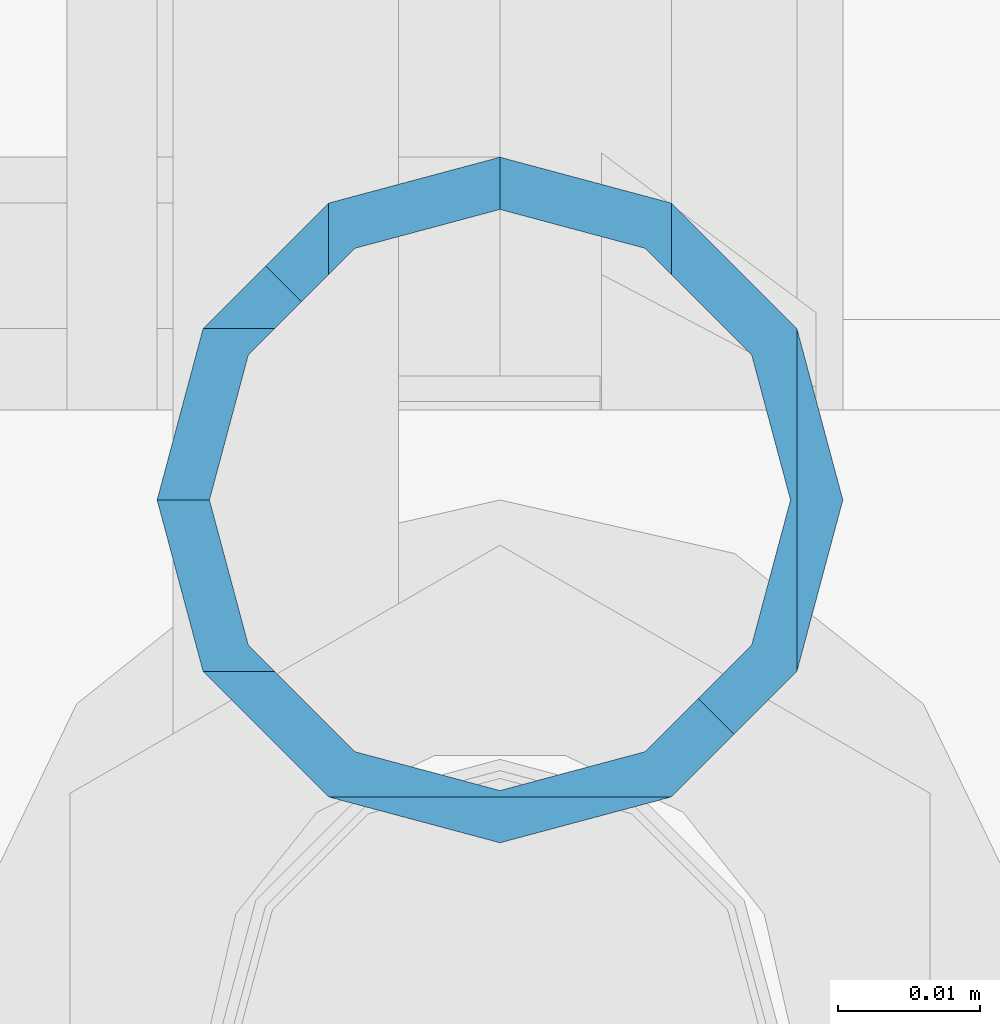
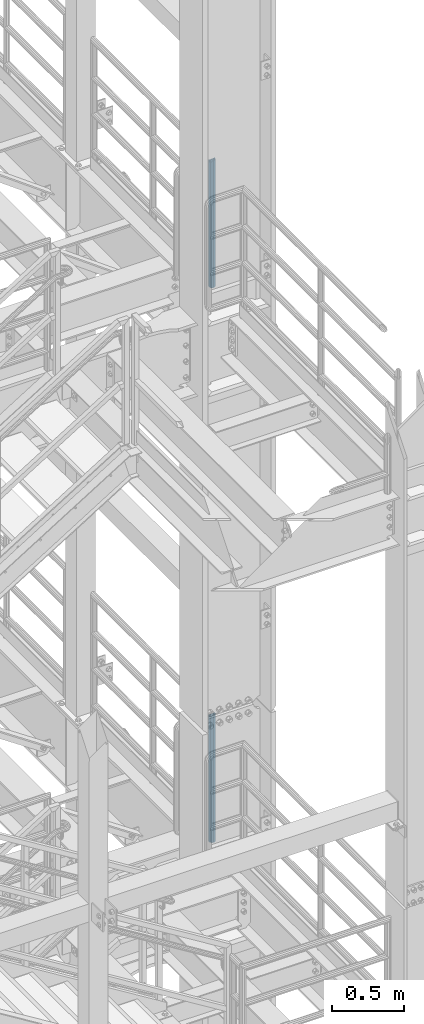
# One storey, part 662 of 1876: 2 columns, 2 elements without a shape of their own.
"""IFC2X3 building model written with IfcOpenShell, lengths in millimetres."""

from ifc_helpers import new_model, si_unit, frame, origin_with_axes, place, context, subcontext, project, spatial, faceted_brep, material, type_object, element, aggregate, save


model = new_model("IFC2X3")

# Units and contexts
model_context = context("Model", 3, precision=1e-05, world=origin_with_axes())
body_context = subcontext(model_context, "Body", "Model", "MODEL_VIEW")
ifc_project = project(units=[si_unit("LENGTHUNIT", "METRE", prefix="MILLI"), si_unit("AREAUNIT", "SQUARE_METRE"), si_unit("VOLUMEUNIT", "CUBIC_METRE"), si_unit("MASSUNIT", "GRAM", prefix="KILO"), si_unit("TIMEUNIT", "SECOND"), si_unit("PLANEANGLEUNIT", "RADIAN"), si_unit("SOLIDANGLEUNIT", "STERADIAN"), si_unit("THERMODYNAMICTEMPERATUREUNIT", "DEGREE_CELSIUS"), si_unit("LUMINOUSINTENSITYUNIT", "LUMEN")], contexts=[model_context])

# Site, building, storey
site_placement = place(None, origin_with_axes())
site = spatial("IfcSite", under=ifc_project, at=site_placement, CompositionType="ELEMENT")
building_placement = place(site_placement, origin_with_axes())
building = spatial("IfcBuilding", under=site, at=building_placement, Name="Undefined", CompositionType="ELEMENT")
storey_placement = place(building_placement, origin_with_axes())
storey = spatial("IfcBuildingStorey", under=building, at=storey_placement, Name="Undefined", CompositionType="ELEMENT", Elevation=0.0)

# Assembly, column
assembly_1_placement = place(storey_placement, origin_with_axes())
assembly_1 = element("IfcElementAssembly", 1, at=assembly_1_placement, inside=storey, Name="RAIL", AssemblyPlace="NOTDEFINED", PredefinedType="RIGID_FRAME")
ifc_material = material()
column_type = type_object("IfcColumnType", Name="PIPE1-1/2SCH40", PredefinedType="NOTDEFINED")
column_1_placement = place(assembly_1_placement, frame((7620.0, -4356.10000000001, 17983.2), z_axis=(0.0, 1.0, 0.0), x_axis=(0.0, 0.0, 1.0)))
column_1 = element("IfcColumn", 2, at=column_1_placement, type_object=column_type, material=ifc_material, Name="POST", ObjectType="PIPE1-1/2SCH40", context=body_context, shape_type="Brep", body=[
    faceted_brep([(1076.325, 0.0, -24.1300000000001), (1064.26, 12.065, -20.8971929933186), (1064.26, -12.0650000000001, -20.8971929933186), (1059.84389372908, 16.4810867391852, -16.481106254133), (1057.32835795174, 13.9655509593595, -13.9655704718216), (1061.07042843786, 10.2235000000001, -17.7076214311801), (1063.80980700668, 0.0, -20.4470000000001), (1061.07042843786, -10.2235000000001, -17.7076214311801), (1055.42780700668, -15.8661214311742, -12.065000000006), (1055.42780700668, -20.8971929933184, -12.0649999999996), (1054.93437856882, -17.7076214311801, -10.2235000000001), (1052.195, -20.4470000000001, 0.0), (1052.195, -24.1300000000001, 0.0), (1054.93437856882, -17.7076214311801, 10.2235000000001), (1055.42780700668, -15.8661214311869, 12.0649999999932), (1055.42780700668, -20.8971929933184, 12.0649999999996), (1057.32837749183, -13.9655704718189, 13.9655509593613), (1059.84391327663, -16.4811062541312, 16.481086739188), (1055.42780700668, -12.0650000000001, 15.8661214311805), (1055.42780700668, -12.0650000000001, 20.8971929933186), (1054.93437856882, -10.2235000000001, 17.7076214311801), (1052.195, 0.0, 20.4470000000001), (1052.195, 0.0, 24.1300000000001), (1054.93437856882, 10.2235000000001, 17.7076214311801), (1055.42780700668, 12.0650000000001, 15.8661214311805), (1055.42780700668, 12.0650000000001, 20.8971929933186), (1076.325, 24.1300000000001, 0.0), (1064.26, 20.8971929933184, 12.0649999999996), (1064.25999999999, 20.8971929933186, -12.0649999999996), (1061.07042843786, 17.7076214311803, 10.2235000000001), (1063.80980700668, 20.4469999999999, 0.0), (1061.07042843786, 17.7076214311803, -10.2235000000001), (0.0, -20.8971929933184, -12.0649999999996), (0.0, -12.0650000000001, -20.8971929933186), (-1.45519152283669e-11, 0.0, -24.130000000001), (0.0, 12.0650000000001, -20.8971929933186), (0.0, 20.8971929933184, -12.0649999999996), (0.0, 24.1299999999992, 0.0), (0.0, -20.8971929933184, 12.0649999999996), (0.0, -24.1299999999992, 0.0), (0.0, -12.0650000000001, 20.8971929933186), (-1.45519152283669e-11, 0.0, 24.130000000001), (0.0, 12.0650000000001, 20.8971929933186), (0.0, 20.8971929933184, 12.0649999999996), (0.0, -17.7076214311803, -10.2235000000001), (0.0, -10.2235000000001, -17.7076214311801), (-1.45519152283669e-11, 0.0, -20.4470000000001), (0.0, 10.2235000000001, -17.7076214311801), (0.0, 17.7076214311803, -10.2235000000001), (0.0, 20.4469999999999, 0.0), (0.0, 17.7076214311803, 10.2235000000001), (0.0, 10.2235000000001, 17.7076214311801), (-1.45519152283669e-11, 0.0, 20.4470000000001), (0.0, -10.2235000000001, 17.7076214311801), (0.0, -17.7076214311803, 10.2235000000001), (0.0, -20.4469999999999, 0.0)], [[[0, 1, 2]], [[2, 1, 3, 4, 5, 6, 7, 8, 9]], [[9, 8, 10, 11, 12]], [[12, 11, 13, 14, 15]], [[15, 14, 16, 17]], [[17, 16, 18, 19]], [[19, 18, 20, 21, 22]], [[22, 21, 23, 24, 25]], [[26, 27, 28]], [[25, 24, 29, 30, 31, 4, 3, 28, 27]], [[32, 33, 2, 9]], [[33, 34, 0, 2]], [[34, 35, 1, 0]], [[1, 35, 36, 28, 3]], [[36, 37, 26, 28]], [[38, 39, 12, 15]], [[40, 38, 15, 17, 19]], [[41, 40, 19, 22]], [[42, 41, 22, 25]], [[43, 42, 25, 27]], [[37, 43, 27, 26]], [[39, 32, 9, 12]], [[38, 40, 41, 42, 43, 37, 36, 35, 34, 33, 32, 39], [44, 45, 46, 47, 48, 49, 50, 51, 52, 53, 54, 55]], [[50, 49, 30, 29]], [[23, 51, 50, 29, 24]], [[52, 51, 23, 21]], [[53, 52, 21, 20]], [[13, 54, 53, 20, 18, 16, 14]], [[55, 54, 13, 11]], [[44, 55, 11, 10]], [[45, 44, 10, 8, 7]], [[46, 45, 7, 6]], [[47, 46, 6, 5]], [[48, 47, 5, 4, 31]], [[49, 48, 31, 30]]]),
])
aggregate(assembly_1, [column_1])

assembly_2_placement = place(storey_placement, origin_with_axes())
assembly_2 = element("IfcElementAssembly", 3, at=assembly_2_placement, inside=storey, Name="RAIL", AssemblyPlace="NOTDEFINED", PredefinedType="RIGID_FRAME")
column_2_placement = place(assembly_2_placement, frame((7620.0, -4356.10000000001, 13309.6), z_axis=(0.0, 1.0, 0.0), x_axis=(0.0, 0.0, 1.0)))
column_2 = element("IfcColumn", 4, at=column_2_placement, type_object=column_type, material=ifc_material, Name="POST", ObjectType="PIPE1-1/2SCH40", context=body_context, shape_type="Brep", body=[
    faceted_brep([(1076.325, 0.0, -24.1300000000001), (1064.26, 12.065, -20.8971929933186), (1064.26, -12.0650000000001, -20.8971929933186), (1059.84389372908, 16.4810867391852, -16.481106254133), (1057.32835795174, 13.9655509593595, -13.9655704718216), (1061.07042843786, 10.2235000000001, -17.7076214311801), (1063.80980700668, 0.0, -20.4470000000001), (1061.07042843786, -10.2235000000001, -17.7076214311801), (1055.42780700668, -15.8661214311742, -12.065000000006), (1055.42780700668, -20.8971929933184, -12.0649999999996), (1054.93437856882, -17.7076214311801, -10.2235000000001), (1052.195, -20.4470000000001, 0.0), (1052.195, -24.1300000000001, 0.0), (1054.93437856882, -17.7076214311801, 10.2235000000001), (1055.42780700668, -15.8661214311869, 12.0649999999932), (1055.42780700668, -20.8971929933184, 12.0649999999996), (1057.32837749183, -13.9655704718189, 13.9655509593613), (1059.84391327663, -16.4811062541312, 16.481086739188), (1055.42780700668, -12.0650000000001, 15.8661214311805), (1055.42780700668, -12.0650000000001, 20.8971929933186), (1054.93437856882, -10.2235000000001, 17.7076214311801), (1052.195, 0.0, 20.4470000000001), (1052.195, 0.0, 24.1300000000001), (1054.93437856882, 10.2235000000001, 17.7076214311801), (1055.42780700668, 12.0650000000001, 15.8661214311805), (1055.42780700668, 12.0650000000001, 20.8971929933186), (1076.325, 24.1300000000001, 0.0), (1064.26, 20.8971929933184, 12.0649999999996), (1064.25999999999, 20.8971929933186, -12.0649999999996), (1061.07042843786, 17.7076214311803, 10.2235000000001), (1063.80980700668, 20.4469999999999, 0.0), (1061.07042843786, 17.7076214311803, -10.2235000000001), (0.0, -20.8971929933184, -12.0649999999996), (0.0, -12.0650000000001, -20.8971929933186), (-1.45519152283669e-11, 0.0, -24.130000000001), (0.0, 12.0650000000001, -20.8971929933186), (0.0, 20.8971929933184, -12.0649999999996), (0.0, 24.1299999999992, 0.0), (0.0, -20.8971929933184, 12.0649999999996), (0.0, -24.1299999999992, 0.0), (0.0, -12.0650000000001, 20.8971929933186), (-1.45519152283669e-11, 0.0, 24.130000000001), (0.0, 12.0650000000001, 20.8971929933186), (0.0, 20.8971929933184, 12.0649999999996), (0.0, -17.7076214311803, -10.2235000000001), (0.0, -10.2235000000001, -17.7076214311801), (-1.45519152283669e-11, 0.0, -20.4470000000001), (0.0, 10.2235000000001, -17.7076214311801), (0.0, 17.7076214311803, -10.2235000000001), (0.0, 20.4469999999999, 0.0), (0.0, 17.7076214311803, 10.2235000000001), (0.0, 10.2235000000001, 17.7076214311801), (-1.45519152283669e-11, 0.0, 20.4470000000001), (0.0, -10.2235000000001, 17.7076214311801), (0.0, -17.7076214311803, 10.2235000000001), (0.0, -20.4469999999999, 0.0)], [[[0, 1, 2]], [[2, 1, 3, 4, 5, 6, 7, 8, 9]], [[9, 8, 10, 11, 12]], [[12, 11, 13, 14, 15]], [[15, 14, 16, 17]], [[17, 16, 18, 19]], [[19, 18, 20, 21, 22]], [[22, 21, 23, 24, 25]], [[26, 27, 28]], [[25, 24, 29, 30, 31, 4, 3, 28, 27]], [[32, 33, 2, 9]], [[33, 34, 0, 2]], [[34, 35, 1, 0]], [[1, 35, 36, 28, 3]], [[36, 37, 26, 28]], [[38, 39, 12, 15]], [[40, 38, 15, 17, 19]], [[41, 40, 19, 22]], [[42, 41, 22, 25]], [[43, 42, 25, 27]], [[37, 43, 27, 26]], [[39, 32, 9, 12]], [[38, 40, 41, 42, 43, 37, 36, 35, 34, 33, 32, 39], [44, 45, 46, 47, 48, 49, 50, 51, 52, 53, 54, 55]], [[50, 49, 30, 29]], [[23, 51, 50, 29, 24]], [[52, 51, 23, 21]], [[53, 52, 21, 20]], [[13, 54, 53, 20, 18, 16, 14]], [[55, 54, 13, 11]], [[44, 55, 11, 10]], [[45, 44, 10, 8, 7]], [[46, 45, 7, 6]], [[47, 46, 6, 5]], [[48, 47, 5, 4, 31]], [[49, 48, 31, 30]]]),
])
aggregate(assembly_2, [column_2])

save(model, "model.ifc")
